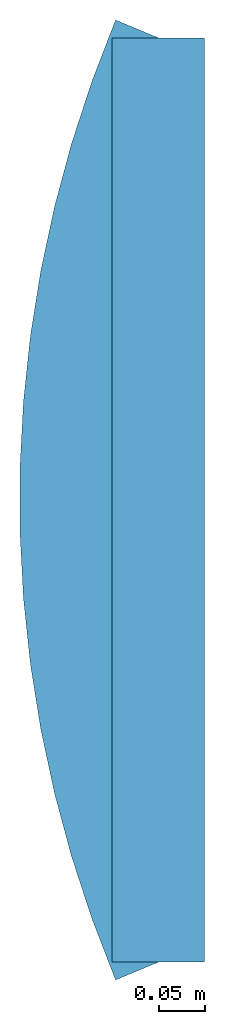
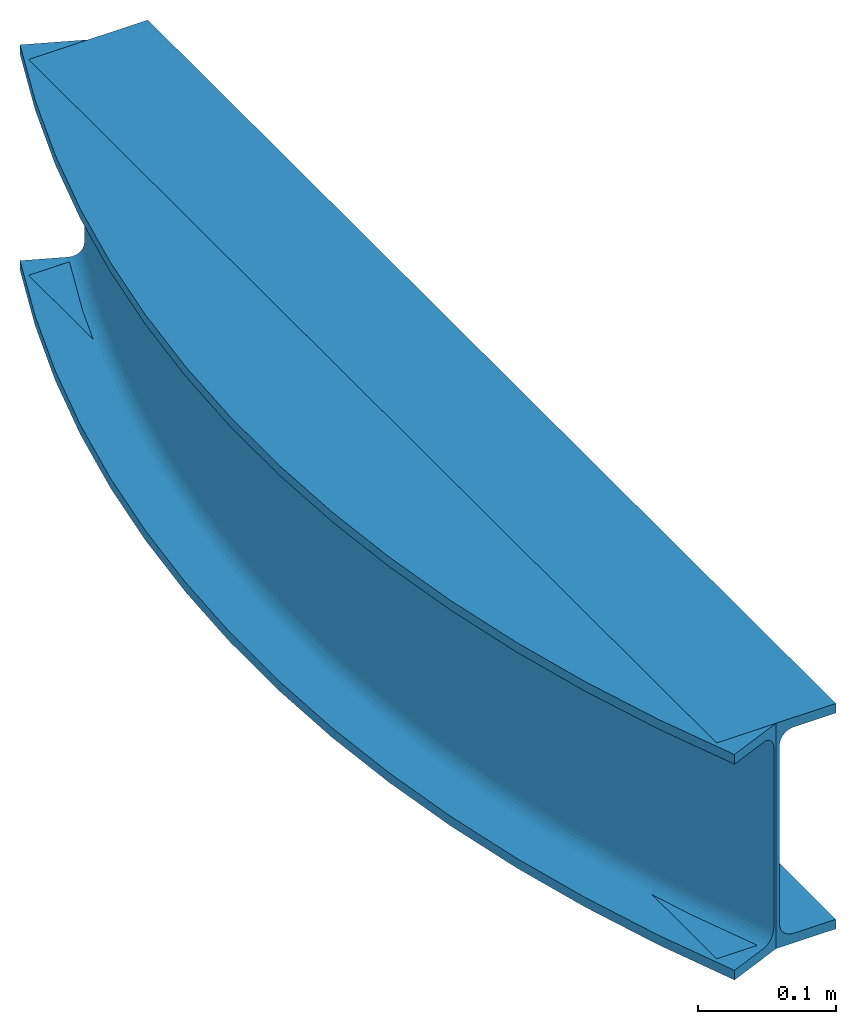
# Not in any storey: 2 beams.
"""IFC4 building model written with IfcOpenShell, lengths in millimetres."""

from ifc_helpers import new_model, entity, si_unit, direction, frame, origin, place, context, subcontext, project, spatial, i_section, extrude, type_object, element, save


model = new_model("IFC4")

# Units and contexts
model_context_1 = context("Model", 3, precision=0.0001, world=origin(), true_north=direction((0.0, 1.0)))
model_context_2 = context("Model", 3, precision=0.0001, world=origin(), true_north=direction((0.0, 1.0)))
body_context = subcontext(model_context_1, "Body", "Model", "MODEL_VIEW")
ifc_project = project(units=[si_unit("LENGTHUNIT", "METRE", prefix="MILLI"), si_unit("PLANEANGLEUNIT", "RADIAN"), si_unit("TIMEUNIT", "SECOND")], contexts=[model_context_2])

# Building
building_placement = place(None, origin())
building = spatial("IfcBuilding", under=ifc_project, at=building_placement, Name="IfcBuilding", CompositionType="ELEMENT")

# Beams
beam_type = type_object("IfcBeamType", Name="IPE200", PredefinedType="JOIST")
beam_1_placement = place(None, frame((0.0, 0.0, 0.0), z_axis=(0.0, 1.0, 0.0), x_axis=(-1.0, 0.0, 0.0)))
element("IfcBeamStandardCase", 1, at=beam_1_placement, inside=building, type_object=beam_type, Name="Extrusion", context=body_context, shape_type="SweptSolid", body=[
    extrude(i_section(OverallWidth=100.0, OverallDepth=200.0, WebThickness=5.6, FlangeThickness=8.5, FilletRadius=12.0), frame((0.0, -100.0, 0.0), z_axis=(0.0, 0.0, 1.0), x_axis=(1.0, 0.0, 0.0)), (0.0, 0.0, 1.0), 1000.0),
])
beam_2_placement = place(None, frame((0.0, 0.0, 0.0), z_axis=(-0.38461538, 0.92307692, 0.0), x_axis=(-0.92307692, -0.38461538, 0.0)))
element("IfcBeamStandardCase", 2, at=beam_2_placement, inside=building, type_object=beam_type, context=body_context, shape_type="SweptSolid", body=[
    entity("IfcRevolvedAreaSolid", entity("IfcIShapeProfileDef", "AREA", None, None, 100.0, 200.0, 5.6, 8.5, 12.0), entity("IfcAxis2Placement3D", entity("IfcCartesianPoint", [0.0, -100.0, 0.0]), entity("IfcDirection", [0.0, 0.0, 1.0]), entity("IfcDirection", [1.0, 0.0, 0.0])), entity("IfcAxis1Placement", entity("IfcCartesianPoint", [-1300.0, 100.0, 0.0]), entity("IfcDirection", [0.0, -1.0, 0.0])), 0.789582239399523),
])

save(model, "model.ifc")
